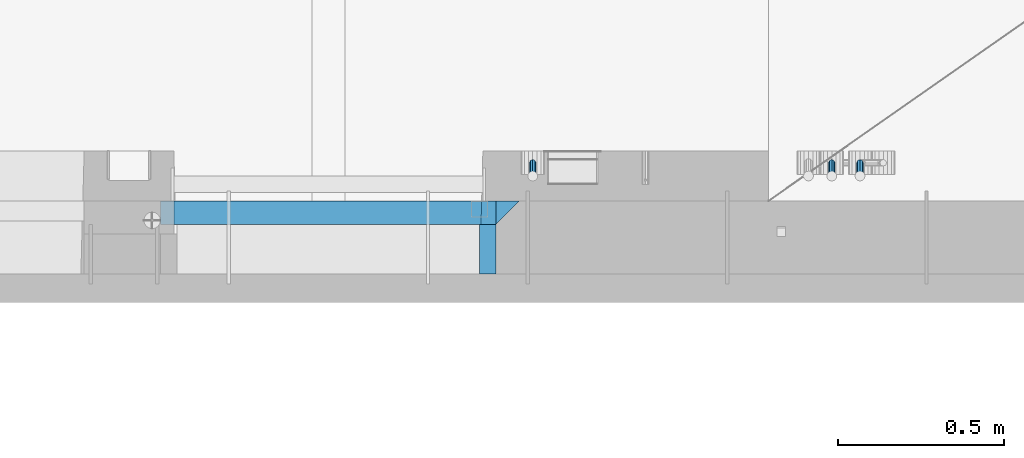
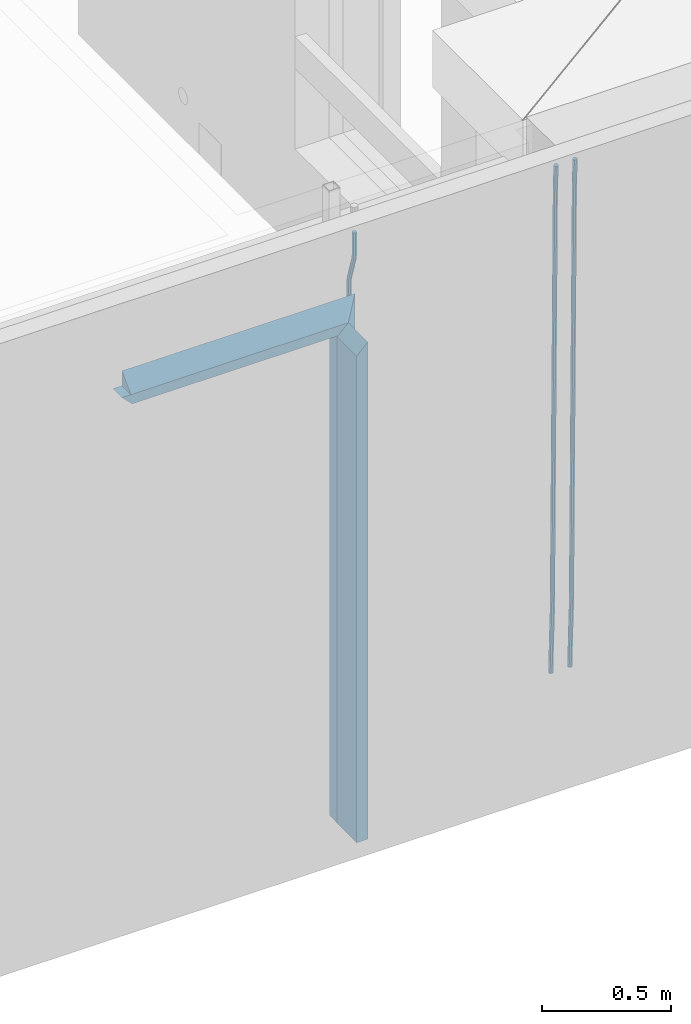
# One storey, part 111 of 309: 8 beams, 1 element without a shape of its own.
"""IFC2X3 building model written with IfcOpenShell, lengths in millimetres."""

from ifc_helpers import new_model, si_unit, frame, origin_with_axes, place, context, subcontext, project, spatial, faceted_brep, material, type_object, element, aggregate, save


model = new_model("IFC2X3")

# Units and contexts
model_context = context("Model", 3, precision=1e-05, world=origin_with_axes())
body_context = subcontext(model_context, "Body", "Model", "MODEL_VIEW")
ifc_project = project(units=[si_unit("LENGTHUNIT", "METRE", prefix="MILLI"), si_unit("AREAUNIT", "SQUARE_METRE"), si_unit("VOLUMEUNIT", "CUBIC_METRE"), si_unit("MASSUNIT", "GRAM", prefix="KILO"), si_unit("TIMEUNIT", "SECOND"), si_unit("PLANEANGLEUNIT", "RADIAN"), si_unit("SOLIDANGLEUNIT", "STERADIAN"), si_unit("THERMODYNAMICTEMPERATUREUNIT", "DEGREE_CELSIUS"), si_unit("LUMINOUSINTENSITYUNIT", "LUMEN")], contexts=[model_context])

# Site, building, storey
site_placement = place(None, origin_with_axes())
site = spatial("IfcSite", under=ifc_project, at=site_placement, CompositionType="ELEMENT")
building_placement = place(site_placement, origin_with_axes())
building = spatial("IfcBuilding", under=site, at=building_placement, CompositionType="ELEMENT")
storey_placement = place(building_placement, origin_with_axes())
storey = spatial("IfcBuildingStorey", under=building, at=storey_placement, Name="7", CompositionType="ELEMENT", Elevation=0.0)

# Assembly, beams
assembly_placement = place(storey_placement, origin_with_axes())
assembly = element("IfcElementAssembly", 1, at=assembly_placement, inside=storey, AssemblyPlace="NOTDEFINED", PredefinedType="REINFORCEMENT_UNIT")
ifc_material_1 = material(Name="CONCRETE/C35/45")
beam_type_1 = type_object("IfcBeamType", PredefinedType="NOTDEFINED")
beam_1_placement = place(assembly_placement, frame((32195.0011811506, 7815.0, 102140.0), z_axis=(0.0, 0.0, -1.0), x_axis=(1.0, 0.0, 0.0)))
beam_1 = element("IfcBeam", 2, at=beam_1_placement, type_object=beam_type_1, material=ifc_material_1, Name="SK", context=body_context, shape_type="Brep", body=[
    faceted_brep([(0.0, -35.0, 35.0), (0.0, 35.0, 35.0), (0.0, -35.0, -35.0), (1039.99771118164, -35.0, -35.0), (969.997711181637, -35.0, 35.0), (969.997711181637, 35.0, 35.0)], [[[0, 1, 2]], [[0, 2, 3, 4]], [[1, 0, 4, 5]], [[2, 1, 5, 3]], [[4, 3, 5]]]),
])
beam_2_placement = place(assembly_placement, frame((33199.9988923323, 7815.0, 102175.0), z_axis=(-1.0, 3.00000001838171e-08, 0.0), x_axis=(0.0, 0.0, -1.0)))
beam_2 = element("IfcBeam", 3, at=beam_2_placement, type_object=beam_type_1, material=ifc_material_1, Name="SK", context=body_context, shape_type="Brep", body=[
    faceted_brep([(2420.0, -35.0, 35.0), (2420.0, -35.0, -35.0), (2420.0, 35.0, 35.0), (0.0, -35.0, -35.0), (70.0000000000164, 35.0, 35.0), (70.0000000000164, -35.0, 35.0)], [[[0, 1, 2]], [[2, 1, 3, 4]], [[0, 2, 4, 5]], [[1, 0, 5, 3]], [[5, 4, 3]]]),
])
beam_type_2 = type_object("IfcBeamType", PredefinedType="NOTDEFINED")
beam_3_placement = place(assembly_placement, frame((32155.0011811506, 7815.0, 102080.0), z_axis=(0.0, 0.0, -1.0), x_axis=(1.0, 0.0, 0.0)))
beam_3 = element("IfcBeam", 4, at=beam_3_placement, type_object=beam_type_2, material=ifc_material_1, Name="SK", context=body_context, shape_type="Brep", body=[
    faceted_brep([(0.0, -35.0, -25.0), (43.8438650277967, -35.0, 18.8461538461561), (45.6387368226679, 35.0, 20.6410256410309), (0.0, 35.0, -25.0), (1009.99771118164, -35.0, -25.0), (966.151557335485, -35.0, 18.8461538461561), (964.356685540617, 35.0, 20.6410256410309), (1009.99771118164, 35.0, -25.0)], [[[0, 1, 2, 3]], [[1, 0, 4, 5]], [[2, 1, 5, 6]], [[3, 2, 6, 7]], [[0, 3, 7, 4]], [[6, 5, 4, 7]]]),
])
beam_4_placement = place(assembly_placement, frame((33139.9988923323, 7815.0, 102105.0), z_axis=(-1.0, 3.00000001838171e-08, 0.0), x_axis=(0.0, 0.0, -1.0)))
beam_4 = element("IfcBeam", 5, at=beam_4_placement, type_object=beam_type_2, material=ifc_material_1, Name="SK", context=body_context, shape_type="Brep", body=[
    faceted_brep([(2350.0, -35.0, -25.0), (2350.0, 35.0, -25.0), (2350.0, 35.0, 20.6410256410309), (2350.0, -35.0, 18.8461538461561), (0.0, -35.0, -25.0), (0.0, 35.0, -25.0), (45.6410256410309, 35.0, 20.6410256410254), (43.8461538461561, -35.0, 18.8461538461543)], [[[0, 1, 2, 3]], [[1, 0, 4, 5]], [[2, 1, 5, 6]], [[3, 2, 6, 7]], [[0, 3, 7, 4]], [[6, 5, 4, 7]]]),
])
ifc_material_2 = material(Name="TIMBER")
beam_type_3 = type_object("IfcBeamType", Name="50X150", PredefinedType="NOTDEFINED")
beam_5_placement = place(assembly_placement, frame((33139.9988923323, 7705.0, 102105.0), z_axis=(-1.0, 3.00000001838171e-08, 0.0), x_axis=(0.0, 0.0, -1.0)))
beam_5 = element("IfcBeam", 6, at=beam_5_placement, type_object=beam_type_3, material=ifc_material_2, ObjectType="50X150", context=body_context, shape_type="Brep", body=[
    faceted_brep([(2345.0, -75.0, 25.0), (2345.0, -75.0, -25.0), (2345.0, 75.0, -25.0), (2345.0, 75.0, 25.0), (0.0, -75.0, -25.0), (0.0, 75.0, -25.0), (50.0000000000036, 75.0, 25.0), (50.0000000000036, -75.0, 25.0)], [[[0, 1, 2, 3]], [[4, 5, 2, 1]], [[3, 2, 5, 6]], [[0, 3, 6, 7]], [[1, 0, 7, 4]], [[7, 6, 5, 4]]]),
])
ifc_material_3 = material()
beam_type_4 = type_object("IfcBeamType", Name="D20", PredefinedType="NOTDEFINED")
beam_6_placement = place(assembly_placement, frame((33274.9999999916, 7925.0, 102407.5), z_axis=(0.000415599999849905, 0.999999913638203, 4.76000000899737e-07), x_axis=(0.0, 0.0, -1.0)))
beam_6 = element("IfcBeam", 7, at=beam_6_placement, type_object=beam_type_4, material=ifc_material_3, Name="JM20", ObjectType="D20", context=body_context, shape_type="Brep", body=[
    faceted_brep([(0.0, -10.0, 0.0), (-4.19531716033816e-08, -7.07106781186667, -7.07106781187031), (113.248091332178, -7.0710684840451, -7.0710678117357), (113.248091314759, -10.0000006713562, -2.51020537689328e-10), (0.0, 0.0, -10.0), (113.248091374131, -6.72178430249915e-07, -9.99999999986903), (4.196772351861e-08, 7.07106781186303, -7.07106781186667), (113.248091416113, 7.07106713968824, -7.07106781173934), (0.0, 10.0, 0.0), (113.248091433488, 9.99999932782521, 1.30967237055302e-10), (4.196772351861e-08, 7.07106781185939, 7.07106781185939), (113.248091416113, 7.0710671396846, 7.071067811994), (0.0, 0.0, 10.0), (113.248091374131, -6.72174792271107e-07, 10.0000000001273), (-4.19531716033816e-08, -7.07106781187031, 7.07106781185939), (113.248091332178, -7.0710684840451, 7.071067811994), (130.699843527167, -7.06993249763036, -4.33745683788584), (128.538066582521, -9.99900540317321, 2.39499413731755), (131.594536475241, 0.00119355250353692, -7.12624594330919), (130.698046432328, 7.07220300913468, -4.33773834422391), (128.535525107087, 10.0009944322555, 2.39459602660281), (126.373748162892, 7.07192152754578, 9.1270470011732), (125.479055214906, 0.000795477419160306, 11.9158361066184), (126.37554525779, -7.07021397921199, 9.12732850753673), (240.336258550378, -7.05529970173666, 30.8729495437874), (238.174481606227, -9.98437260450009, 37.6054005176375), (241.230951498423, 0.0158263482953771, 28.0841604381058), (240.334461455612, 7.0868358050102, 30.8726680369582), (238.171940130502, 10.0156272283348, 37.6050024077231), (236.010163186409, 7.08655432384694, 44.3374533824244), (235.115470238379, 0.0154282738185429, 47.1262424881097), (236.011960281176, -7.05558118289991, 44.3377348892536), (253.461915329972, -7.05444528127919, 32.9289287376414), (253.46191532613, -9.98337746617108, 39.9999965521893), (253.461915339081, 0.0166225284556276, 29.9999965443676), (253.461915348205, 7.08769034247234, 32.9289287273205), (253.461915352003, 10.0166225357716, 39.9999965370152), (253.461915348293, 7.08769035281148, 47.0710643509774), (253.461915339183, 0.0166225430875784, 49.999996544273), (253.46191533003, -7.05444527093641, 47.0710643613093), (2417.50000002384, -7.0544364694706, 32.9289287374122), (2417.5000000337, -9.98336865393321, 39.9999965507959), (2417.49999999997, 0.0166313408753922, 29.9999965456082), (2417.49999997609, 7.08769915426274, 32.9289287300708), (2417.4999999662, 10.0166313460668, 39.9999965404204), (2417.49999997608, 7.08769916160054, 47.0710643538114), (2417.49999999994, 0.0166313512581837, 49.9999965456154), (2417.50000002382, -7.05443646212916, 47.0710643611455)], [[[0, 1, 2, 3]], [[1, 4, 5, 2]], [[4, 6, 7, 5]], [[6, 8, 9, 7]], [[8, 10, 11, 9]], [[10, 12, 13, 11]], [[12, 14, 15, 13]], [[14, 0, 3, 15]], [[14, 12, 10, 8, 6, 4, 1, 0]], [[3, 2, 16, 17]], [[2, 5, 18, 16]], [[5, 7, 19, 18]], [[7, 9, 20, 19]], [[9, 11, 21, 20]], [[11, 13, 22, 21]], [[13, 15, 23, 22]], [[15, 3, 17, 23]], [[17, 16, 24, 25]], [[16, 18, 26, 24]], [[18, 19, 27, 26]], [[19, 20, 28, 27]], [[20, 21, 29, 28]], [[21, 22, 30, 29]], [[22, 23, 31, 30]], [[23, 17, 25, 31]], [[25, 24, 32, 33]], [[24, 26, 34, 32]], [[26, 27, 35, 34]], [[27, 28, 36, 35]], [[28, 29, 37, 36]], [[29, 30, 38, 37]], [[30, 31, 39, 38]], [[31, 25, 33, 39]], [[33, 32, 40, 41]], [[32, 34, 42, 40]], [[34, 35, 43, 42]], [[35, 36, 44, 43]], [[36, 37, 45, 44]], [[37, 38, 46, 45]], [[38, 39, 47, 46]], [[39, 33, 41, 47]], [[42, 43, 44, 45, 46, 47, 41, 40]]]),
])
beam_7_placement = place(assembly_placement, frame((34259.9999999961, 7965.00000227913, 99990.0), z_axis=(0.00020576299992186, -0.999642804629538, -0.0267249099901004), x_axis=(-4.30000201928125e-08, -0.0267249099948059, 0.999642825806181)))
beam_7 = element("IfcBeam", 8, at=beam_7_placement, type_object=beam_type_4, material=ifc_material_3, Name="JM20", ObjectType="D20", context=body_context, shape_type="Brep", body=[
    faceted_brep([(0.0, -10.0, 0.0), (-4.19531716033816e-08, -7.07106781186667, -7.07106781187031), (60.4266690400545, -7.0710677960451, -7.07106780570757), (60.4266690441291, -9.99999998418934, 6.15546014159918e-09), (0.0, 0.0, -10.0), (60.426669036824, 1.58106558956206e-08, -9.99999999384454), (4.196772351861e-08, 7.07106781186303, -7.07106781186667), (60.4266690363438, 7.07106782768096, -7.07106780570757), (0.0, 10.0, 0.0), (60.4266690388904, 10.0000000158179, 6.15182216279209e-09), (4.196772351861e-08, 7.07106781185939, 7.07106781185939), (60.4266690429649, 7.07106782768096, 7.07106781802577), (0.0, 0.0, 10.0), (60.4266690461809, 1.58179318532348e-08, 10.0000000061555), (-4.19531716033816e-08, -7.07106781187031, 7.07106781185939), (60.4266690466611, -7.07106779605238, 7.07106781802213), (61.0378400410118, -7.07106779588503, -7.07106780564936), (60.991799419251, -9.99999998403655, 6.21366780251265e-09), (61.0569027789461, 1.5985278878361e-08, -9.99999999378269), (61.0378209396877, 7.07106782784831, -7.07106780564936), (60.9917724058905, 10.0000000159635, 6.21366780251265e-09), (60.9457317841297, 7.07106782781193, 7.0710678180767), (60.9266690461809, 1.59488990902901e-08, 10.0000000062028), (60.9457508854539, -7.07106779591413, 7.0710678180767), (61.6489592143771, -7.07106614513759, -7.06310863441468), (61.5568818710308, -9.9999984576425, 0.00735959856683621), (61.6870830769039, 1.71821739058942e-06, -9.99179257185824), (61.6489210170112, 7.07106947854481, -7.06310888312146), (61.556827851804, 10.0000015422847, 0.00735924683976918), (61.4647505084577, 7.07106922979438, 7.07782747982128), (61.4266266459163, 1.36643211590126e-06, 10.0065114172685), (61.464788705809, -7.07106639389531, 7.07782772852806), (176.543135720174, -7.07075579406956, -5.56673531796696), (176.451058376813, -9.99968810657447, 1.50373291501455), (176.581259582701, 0.000312069292704109, -8.49541925541052), (176.543097522794, 7.07137982961285, -5.56673556667374), (176.451004357587, 10.00031189336, 1.50373256329476), (176.35892701424, 7.07137958085514, 8.57420079627263), (176.320803151699, 0.000311717507429421, 11.5028847337162), (176.358965211621, -7.07075604281999, 8.57420104497578), (177.098753836006, -7.07075429323595, -5.55949898843028), (176.98362511232, -9.99968666800123, 1.510669025065), (177.146421932586, 0.000313595905026887, -8.48805862247536), (177.098706077581, 7.07138133041735, -5.55949936166144), (176.983557571715, 10.0003133318824, 1.51066849724157), (176.868428848029, 7.07138095712435, 8.58083651073321), (176.820760751449, 0.000313067976094317, 11.5093961447819), (176.868476606425, -7.07075466652896, 8.58083688396073), (177.654312950661, -7.07075204110879, -5.54863964998367), (177.516135294456, -9.99968450931192, 1.52107783331303), (177.711524267797, 0.000315886711177882, -8.47701274570863), (177.654255632195, 7.07138358250813, -5.54864021007961), (177.516054233929, 10.0003154905207, 1.5210770412159), (177.377876577739, 7.0713830223176, 8.59079452451624), (177.320665260588, 0.000315094497636892, 11.5191676202448), (177.377933896176, -7.07075260129932, 8.59079508461218), (299.436796249574, -7.07025836271714, -3.1681962331204), (299.298618593355, -9.99919083092027, 3.90152125031091), (299.494007566798, 0.000809565110102994, -6.09656932889993), (299.436738931283, 7.07187726089978, -3.16819679320906), (299.298537533061, 10.0008091689197, 3.90152045822106), (299.160359876842, 7.07187670072017, 10.9712379416487), (299.103148559603, 0.000808772889286047, 13.8996110374392), (299.160417195119, -7.07025892290039, 10.9712385017483), (299.98743051647, -7.07025613056248, -3.15743315966392), (299.971788958996, -9.99918809853989, 3.91467979818117), (299.993912075952, 0.000811591617093654, -6.08679785393178), (299.987423933868, 7.07187949325817, -3.1574327280432), (299.971753863239, 10.0008119014747, 3.91467990454839), (299.95611230444, 7.07187992653053, 10.9867922621015), (299.949630744944, 0.000812204350950196, 13.9161569563694), (299.956118887014, -7.07025569729012, 10.9867918304735), (300.538107039494, -7.07025785017686, -3.16575821840888), (300.644985195438, -9.99919020432935, 3.90450175465594), (300.493854948218, 0.000810030429420294, -6.09435592770024), (300.538151196495, 7.071877773491, -3.16575855385963), (300.645047642858, 10.0008097955724, 3.90450128024895), (300.751925798773, 7.07187744142357, 10.9747612533101), (300.796177890064, 0.000809560813650023, 13.9033589625978), (300.751881641787, -7.07025818224065, 10.9747615887682), (2293.36490490142, -7.07648090940347, -33.2930642912361), (2293.47178305736, -10.0054132635523, -26.2228043181785), (2293.32065281013, -0.00541302880083094, -36.2216620005347), (2293.36494905842, 7.06565471425711, -33.2930646266868), (2293.47184550477, 9.99458673634581, -26.2228047925819), (2293.57872366071, 7.06565438219332, -19.1525448195243), (2293.62297575199, -0.00541349841296324, -16.2239471102366), (2293.57867950371, -7.0764812414709, -19.1525444840736), (2294.0658245362, -7.07648309818615, -33.3036607065333), (2294.05312277409, -10.0054150789219, -26.2315929392535), (2294.10928714235, -0.00541549149056664, -36.2335844756526), (2294.15805078732, 7.06565223761572, -33.3050546393533), (2294.18355038921, 9.99458451388637, -26.2335642579346), (2294.17084862708, 7.06565253314329, -19.1614964906439), (2294.12738602093, -0.00541507354500936, -16.2315727215355), (2294.07862237596, -7.07648280265857, -19.1601025578348), (2294.76670261032, -7.08562269121467, -33.294332712383), (2294.63442802057, -10.0129954178956, -26.2238563411993), (2294.89787471293, -0.0156988342423574, -36.2230891548279), (2294.95110548967, 7.05531064255774, -33.2944998654275), (2294.89521307347, 9.98530428734011, -26.2240927312887), (2294.76293848372, 7.0579315606592, -19.1536163601049), (2294.63176638114, -0.0119922963167483, -16.2248599176673), (2294.57853560438, -7.08300177311321, -19.1534492070678), (2316.52657204497, -7.36937582653991, -33.0047303660212), (2316.39429745522, -10.2967485532172, -25.9342539948302), (2316.65774414754, -0.299451969567599, -35.9334868084661), (2316.7109749243, 6.7715575072325, -33.0048975190657), (2316.65508250811, 9.70155115201487, -25.9344903849269), (2316.52280791836, 6.7741784253376, -18.8640140137468), (2316.39163581574, -0.295745431634714, -15.9352575713092), (2316.33840503903, -7.36675490843481, -18.863846860706), (2317.16202064224, -7.37766220584308, -32.9962731735213), (2317.05438744847, -10.3053562613532, -25.9254688497131), (2317.23607125619, -0.306993473008333, -35.925789846493), (2317.23316144495, 6.76474808850253, -32.9979477328052), (2317.15499573652, 9.6950321815566, -25.9278370341635), (2317.04736254275, 6.7673381260538, -18.8570327103698), (2316.97331192881, -0.303330606784584, -15.9275160373909), (2316.97622174003, -7.37507216829545, -18.8553581510787), (2317.79752306276, -7.37578610372293, -32.9880110666527), (2317.71453320107, -10.3033876998124, -25.9168792378296), (2317.81444760226, -0.305295583297266, -35.918287695793), (2317.75539265381, 6.76628640723357, -32.9911928173897), (2317.65495180529, 9.69652304524061, -25.9213789128698), (2317.5719619436, 6.76892144914746, -18.8502470840467), (2317.55503740412, -0.301569071270933, -15.9199704549137), (2317.61409235255, -7.3731510618054, -18.847065333317), (2417.8183084176, -7.07752398473531, -31.6906369377139), (2417.73531855589, -10.0051255808248, -24.6195051088798), (2417.83523295709, -0.007033464313281, -34.6209135668432), (2417.77617800863, 7.06454852621755, -31.6938186884508), (2417.67573716014, 9.99478516423187, -24.6240047839383), (2417.59274729842, 7.06718356813872, -17.5528729551006), (2417.57582275895, -0.00330695228694822, -14.6225963259749), (2417.6348777074, -7.07488894281778, -17.5496912043673)], [[[0, 1, 2, 3]], [[1, 4, 5, 2]], [[4, 6, 7, 5]], [[6, 8, 9, 7]], [[8, 10, 11, 9]], [[10, 12, 13, 11]], [[12, 14, 15, 13]], [[14, 0, 3, 15]], [[14, 12, 10, 8, 6, 4, 1, 0]], [[3, 2, 16, 17]], [[2, 5, 18, 16]], [[5, 7, 19, 18]], [[7, 9, 20, 19]], [[9, 11, 21, 20]], [[11, 13, 22, 21]], [[13, 15, 23, 22]], [[15, 3, 17, 23]], [[17, 16, 24, 25]], [[16, 18, 26, 24]], [[18, 19, 27, 26]], [[19, 20, 28, 27]], [[20, 21, 29, 28]], [[21, 22, 30, 29]], [[22, 23, 31, 30]], [[23, 17, 25, 31]], [[25, 24, 32, 33]], [[24, 26, 34, 32]], [[26, 27, 35, 34]], [[27, 28, 36, 35]], [[28, 29, 37, 36]], [[29, 30, 38, 37]], [[30, 31, 39, 38]], [[31, 25, 33, 39]], [[33, 32, 40, 41]], [[32, 34, 42, 40]], [[34, 35, 43, 42]], [[35, 36, 44, 43]], [[36, 37, 45, 44]], [[37, 38, 46, 45]], [[38, 39, 47, 46]], [[39, 33, 41, 47]], [[41, 40, 48, 49]], [[40, 42, 50, 48]], [[42, 43, 51, 50]], [[43, 44, 52, 51]], [[44, 45, 53, 52]], [[45, 46, 54, 53]], [[46, 47, 55, 54]], [[47, 41, 49, 55]], [[49, 48, 56, 57]], [[48, 50, 58, 56]], [[50, 51, 59, 58]], [[51, 52, 60, 59]], [[52, 53, 61, 60]], [[53, 54, 62, 61]], [[54, 55, 63, 62]], [[55, 49, 57, 63]], [[57, 56, 64, 65]], [[56, 58, 66, 64]], [[58, 59, 67, 66]], [[59, 60, 68, 67]], [[60, 61, 69, 68]], [[61, 62, 70, 69]], [[62, 63, 71, 70]], [[63, 57, 65, 71]], [[65, 64, 72, 73]], [[64, 66, 74, 72]], [[66, 67, 75, 74]], [[67, 68, 76, 75]], [[68, 69, 77, 76]], [[69, 70, 78, 77]], [[70, 71, 79, 78]], [[71, 65, 73, 79]], [[73, 72, 80, 81]], [[72, 74, 82, 80]], [[74, 75, 83, 82]], [[75, 76, 84, 83]], [[76, 77, 85, 84]], [[77, 78, 86, 85]], [[78, 79, 87, 86]], [[79, 73, 81, 87]], [[81, 80, 88, 89]], [[80, 82, 90, 88]], [[82, 83, 91, 90]], [[83, 84, 92, 91]], [[84, 85, 93, 92]], [[85, 86, 94, 93]], [[86, 87, 95, 94]], [[87, 81, 89, 95]], [[89, 88, 96, 97]], [[88, 90, 98, 96]], [[90, 91, 99, 98]], [[91, 92, 100, 99]], [[92, 93, 101, 100]], [[93, 94, 102, 101]], [[94, 95, 103, 102]], [[95, 89, 97, 103]], [[97, 96, 104, 105]], [[96, 98, 106, 104]], [[98, 99, 107, 106]], [[99, 100, 108, 107]], [[100, 101, 109, 108]], [[101, 102, 110, 109]], [[102, 103, 111, 110]], [[103, 97, 105, 111]], [[105, 104, 112, 113]], [[104, 106, 114, 112]], [[106, 107, 115, 114]], [[107, 108, 116, 115]], [[108, 109, 117, 116]], [[109, 110, 118, 117]], [[110, 111, 119, 118]], [[111, 105, 113, 119]], [[113, 112, 120, 121]], [[112, 114, 122, 120]], [[114, 115, 123, 122]], [[115, 116, 124, 123]], [[116, 117, 125, 124]], [[117, 118, 126, 125]], [[118, 119, 127, 126]], [[119, 113, 121, 127]], [[121, 120, 128, 129]], [[120, 122, 130, 128]], [[122, 123, 131, 130]], [[123, 124, 132, 131]], [[124, 125, 133, 132]], [[125, 126, 134, 133]], [[126, 127, 135, 134]], [[127, 121, 129, 135]], [[130, 131, 132, 133, 134, 135, 129, 128]]]),
])
beam_8_placement = place(assembly_placement, frame((34174.9999999961, 7965.00000227913, 99990.0), z_axis=(0.00020576299992186, -0.999642804629538, -0.0267249099901004), x_axis=(-4.30000201928125e-08, -0.0267249099948059, 0.999642825806181)))
beam_8 = element("IfcBeam", 9, at=beam_8_placement, type_object=beam_type_4, material=ifc_material_3, Name="JM20", ObjectType="D20", context=body_context, shape_type="Brep", body=[
    faceted_brep([(0.0, -10.0, 0.0), (-4.19531716033816e-08, -7.07106781186667, -7.07106781187031), (60.4266690400545, -7.0710677960451, -7.07106780570757), (60.4266690441291, -9.99999998418934, 6.15546014159918e-09), (0.0, 0.0, -10.0), (60.426669036824, 1.58106558956206e-08, -9.99999999384454), (4.196772351861e-08, 7.07106781186303, -7.07106781186667), (60.4266690363438, 7.07106782768096, -7.07106780570757), (0.0, 10.0, 0.0), (60.4266690388904, 10.0000000158179, 6.15182216279209e-09), (4.196772351861e-08, 7.07106781185939, 7.07106781185939), (60.4266690429649, 7.07106782768096, 7.07106781802577), (0.0, 0.0, 10.0), (60.4266690461809, 1.58179318532348e-08, 10.0000000061555), (-4.19531716033816e-08, -7.07106781187031, 7.07106781185939), (60.4266690466611, -7.07106779605238, 7.07106781802213), (61.0378400410118, -7.07106779588503, -7.07106780564936), (60.991799419251, -9.99999998403655, 6.21366780251265e-09), (61.0569027789461, 1.5985278878361e-08, -9.99999999378269), (61.0378209396877, 7.07106782784831, -7.07106780564936), (60.9917724058905, 10.0000000159635, 6.21366780251265e-09), (60.9457317841297, 7.07106782781193, 7.0710678180767), (60.9266690461809, 1.59488990902901e-08, 10.0000000062028), (60.9457508854539, -7.07106779591413, 7.0710678180767), (61.6489592143771, -7.07106614513759, -7.06310863441468), (61.5568818710308, -9.9999984576425, 0.00735959856683621), (61.6870830769039, 1.71821739058942e-06, -9.99179257185824), (61.6489210170112, 7.07106947854481, -7.06310888312146), (61.556827851804, 10.0000015422847, 0.00735924683976918), (61.4647505084577, 7.07106922979438, 7.07782747982128), (61.4266266459163, 1.36643211590126e-06, 10.0065114172685), (61.464788705809, -7.07106639389531, 7.07782772852806), (176.543135720174, -7.07075579406956, -5.56673531796696), (176.451058376813, -9.99968810657447, 1.50373291501455), (176.581259582701, 0.000312069292704109, -8.49541925541052), (176.543097522794, 7.07137982961285, -5.56673556667374), (176.451004357587, 10.00031189336, 1.50373256329476), (176.35892701424, 7.07137958085514, 8.57420079627263), (176.320803151699, 0.000311717507429421, 11.5028847337162), (176.358965211621, -7.07075604281999, 8.57420104497578), (177.098753836006, -7.07075429323595, -5.55949898843028), (176.98362511232, -9.99968666800123, 1.510669025065), (177.146421932586, 0.000313595905026887, -8.48805862247536), (177.098706077581, 7.07138133041735, -5.55949936166144), (176.983557571715, 10.0003133318824, 1.51066849724157), (176.868428848029, 7.07138095712435, 8.58083651073321), (176.820760751449, 0.000313067976094317, 11.5093961447819), (176.868476606425, -7.07075466652896, 8.58083688396073), (177.654312950661, -7.07075204110879, -5.54863964998367), (177.516135294456, -9.99968450931192, 1.52107783331303), (177.711524267797, 0.000315886711177882, -8.47701274570863), (177.654255632195, 7.07138358250813, -5.54864021007961), (177.516054233929, 10.0003154905207, 1.5210770412159), (177.377876577739, 7.0713830223176, 8.59079452451624), (177.320665260588, 0.000315094497636892, 11.5191676202448), (177.377933896176, -7.07075260129932, 8.59079508461218), (299.436796249574, -7.07025836271714, -3.1681962331204), (299.298618593355, -9.99919083092027, 3.90152125031091), (299.494007566798, 0.000809565110102994, -6.09656932889993), (299.436738931283, 7.07187726089978, -3.16819679320906), (299.298537533061, 10.0008091689197, 3.90152045822106), (299.160359876842, 7.07187670072017, 10.9712379416487), (299.103148559603, 0.000808772889286047, 13.8996110374392), (299.160417195119, -7.07025892290039, 10.9712385017483), (299.98743051647, -7.07025613056248, -3.15743315966392), (299.971788958996, -9.99918809853989, 3.91467979818117), (299.993912075952, 0.000811591617093654, -6.08679785393178), (299.987423933868, 7.07187949325817, -3.1574327280432), (299.971753863239, 10.0008119014747, 3.91467990454839), (299.95611230444, 7.07187992653053, 10.9867922621015), (299.949630744944, 0.000812204350950196, 13.9161569563694), (299.956118887014, -7.07025569729012, 10.9867918304735), (300.538107039494, -7.07025785017686, -3.16575821840888), (300.644985195438, -9.99919020432935, 3.90450175465594), (300.493854948218, 0.000810030429420294, -6.09435592770024), (300.538151196495, 7.071877773491, -3.16575855385963), (300.645047642858, 10.0008097955724, 3.90450128024895), (300.751925798773, 7.07187744142357, 10.9747612533101), (300.796177890064, 0.000809560813650023, 13.9033589625978), (300.751881641787, -7.07025818224065, 10.9747615887682), (2293.36490490142, -7.07648090940347, -33.2930642912361), (2293.47178305736, -10.0054132635523, -26.2228043181785), (2293.32065281013, -0.00541302880083094, -36.2216620005347), (2293.36494905842, 7.06565471425711, -33.2930646266868), (2293.47184550477, 9.99458673634581, -26.2228047925819), (2293.57872366071, 7.06565438219332, -19.1525448195243), (2293.62297575199, -0.00541349841296324, -16.2239471102366), (2293.57867950371, -7.0764812414709, -19.1525444840736), (2294.0658245362, -7.07648309818615, -33.3036607065333), (2294.05312277409, -10.0054150789219, -26.2315929392535), (2294.10928714235, -0.00541549149056664, -36.2335844756526), (2294.15805078732, 7.06565223761572, -33.3050546393533), (2294.18355038921, 9.99458451388637, -26.2335642579346), (2294.17084862708, 7.06565253314329, -19.1614964906439), (2294.12738602093, -0.00541507354500936, -16.2315727215355), (2294.07862237596, -7.07648280265857, -19.1601025578348), (2294.76670261032, -7.08562269121467, -33.294332712383), (2294.63442802057, -10.0129954178956, -26.2238563411993), (2294.89787471293, -0.0156988342423574, -36.2230891548279), (2294.95110548967, 7.05531064255774, -33.2944998654275), (2294.89521307347, 9.98530428734011, -26.2240927312887), (2294.76293848372, 7.0579315606592, -19.1536163601049), (2294.63176638114, -0.0119922963167483, -16.2248599176673), (2294.57853560438, -7.08300177311321, -19.1534492070678), (2316.52657204497, -7.36937582653991, -33.0047303660212), (2316.39429745522, -10.2967485532172, -25.9342539948302), (2316.65774414754, -0.299451969567599, -35.9334868084661), (2316.7109749243, 6.7715575072325, -33.0048975190657), (2316.65508250811, 9.70155115201487, -25.9344903849269), (2316.52280791836, 6.7741784253376, -18.8640140137468), (2316.39163581574, -0.295745431634714, -15.9352575713092), (2316.33840503903, -7.36675490843481, -18.863846860706), (2317.16202064224, -7.37766220584308, -32.9962731735213), (2317.05438744847, -10.3053562613532, -25.9254688497131), (2317.23607125619, -0.306993473008333, -35.925789846493), (2317.23316144495, 6.76474808850253, -32.9979477328052), (2317.15499573652, 9.6950321815566, -25.9278370341635), (2317.04736254275, 6.7673381260538, -18.8570327103698), (2316.97331192881, -0.303330606784584, -15.9275160373909), (2316.97622174003, -7.37507216829545, -18.8553581510787), (2317.79752306276, -7.37578610372293, -32.9880110666527), (2317.71453320107, -10.3033876998124, -25.9168792378296), (2317.81444760226, -0.305295583297266, -35.918287695793), (2317.75539265381, 6.76628640723357, -32.9911928173897), (2317.65495180529, 9.69652304524061, -25.9213789128698), (2317.5719619436, 6.76892144914746, -18.8502470840467), (2317.55503740412, -0.301569071270933, -15.9199704549137), (2317.61409235255, -7.3731510618054, -18.847065333317), (2417.8183084176, -7.07752398473531, -31.6906369377139), (2417.73531855589, -10.0051255808248, -24.6195051088798), (2417.83523295709, -0.007033464313281, -34.6209135668432), (2417.77617800863, 7.06454852621755, -31.6938186884508), (2417.67573716014, 9.99478516423187, -24.6240047839383), (2417.59274729842, 7.06718356813872, -17.5528729551006), (2417.57582275895, -0.00330695228694822, -14.6225963259749), (2417.6348777074, -7.07488894281778, -17.5496912043673)], [[[0, 1, 2, 3]], [[1, 4, 5, 2]], [[4, 6, 7, 5]], [[6, 8, 9, 7]], [[8, 10, 11, 9]], [[10, 12, 13, 11]], [[12, 14, 15, 13]], [[14, 0, 3, 15]], [[14, 12, 10, 8, 6, 4, 1, 0]], [[3, 2, 16, 17]], [[2, 5, 18, 16]], [[5, 7, 19, 18]], [[7, 9, 20, 19]], [[9, 11, 21, 20]], [[11, 13, 22, 21]], [[13, 15, 23, 22]], [[15, 3, 17, 23]], [[17, 16, 24, 25]], [[16, 18, 26, 24]], [[18, 19, 27, 26]], [[19, 20, 28, 27]], [[20, 21, 29, 28]], [[21, 22, 30, 29]], [[22, 23, 31, 30]], [[23, 17, 25, 31]], [[25, 24, 32, 33]], [[24, 26, 34, 32]], [[26, 27, 35, 34]], [[27, 28, 36, 35]], [[28, 29, 37, 36]], [[29, 30, 38, 37]], [[30, 31, 39, 38]], [[31, 25, 33, 39]], [[33, 32, 40, 41]], [[32, 34, 42, 40]], [[34, 35, 43, 42]], [[35, 36, 44, 43]], [[36, 37, 45, 44]], [[37, 38, 46, 45]], [[38, 39, 47, 46]], [[39, 33, 41, 47]], [[41, 40, 48, 49]], [[40, 42, 50, 48]], [[42, 43, 51, 50]], [[43, 44, 52, 51]], [[44, 45, 53, 52]], [[45, 46, 54, 53]], [[46, 47, 55, 54]], [[47, 41, 49, 55]], [[49, 48, 56, 57]], [[48, 50, 58, 56]], [[50, 51, 59, 58]], [[51, 52, 60, 59]], [[52, 53, 61, 60]], [[53, 54, 62, 61]], [[54, 55, 63, 62]], [[55, 49, 57, 63]], [[57, 56, 64, 65]], [[56, 58, 66, 64]], [[58, 59, 67, 66]], [[59, 60, 68, 67]], [[60, 61, 69, 68]], [[61, 62, 70, 69]], [[62, 63, 71, 70]], [[63, 57, 65, 71]], [[65, 64, 72, 73]], [[64, 66, 74, 72]], [[66, 67, 75, 74]], [[67, 68, 76, 75]], [[68, 69, 77, 76]], [[69, 70, 78, 77]], [[70, 71, 79, 78]], [[71, 65, 73, 79]], [[73, 72, 80, 81]], [[72, 74, 82, 80]], [[74, 75, 83, 82]], [[75, 76, 84, 83]], [[76, 77, 85, 84]], [[77, 78, 86, 85]], [[78, 79, 87, 86]], [[79, 73, 81, 87]], [[81, 80, 88, 89]], [[80, 82, 90, 88]], [[82, 83, 91, 90]], [[83, 84, 92, 91]], [[84, 85, 93, 92]], [[85, 86, 94, 93]], [[86, 87, 95, 94]], [[87, 81, 89, 95]], [[89, 88, 96, 97]], [[88, 90, 98, 96]], [[90, 91, 99, 98]], [[91, 92, 100, 99]], [[92, 93, 101, 100]], [[93, 94, 102, 101]], [[94, 95, 103, 102]], [[95, 89, 97, 103]], [[97, 96, 104, 105]], [[96, 98, 106, 104]], [[98, 99, 107, 106]], [[99, 100, 108, 107]], [[100, 101, 109, 108]], [[101, 102, 110, 109]], [[102, 103, 111, 110]], [[103, 97, 105, 111]], [[105, 104, 112, 113]], [[104, 106, 114, 112]], [[106, 107, 115, 114]], [[107, 108, 116, 115]], [[108, 109, 117, 116]], [[109, 110, 118, 117]], [[110, 111, 119, 118]], [[111, 105, 113, 119]], [[113, 112, 120, 121]], [[112, 114, 122, 120]], [[114, 115, 123, 122]], [[115, 116, 124, 123]], [[116, 117, 125, 124]], [[117, 118, 126, 125]], [[118, 119, 127, 126]], [[119, 113, 121, 127]], [[121, 120, 128, 129]], [[120, 122, 130, 128]], [[122, 123, 131, 130]], [[123, 124, 132, 131]], [[124, 125, 133, 132]], [[125, 126, 134, 133]], [[126, 127, 135, 134]], [[127, 121, 129, 135]], [[130, 131, 132, 133, 134, 135, 129, 128]]]),
])
aggregate(assembly, [beam_6, beam_7, beam_8, beam_1, beam_3, beam_2, beam_4, beam_5])

save(model, "model.ifc")
